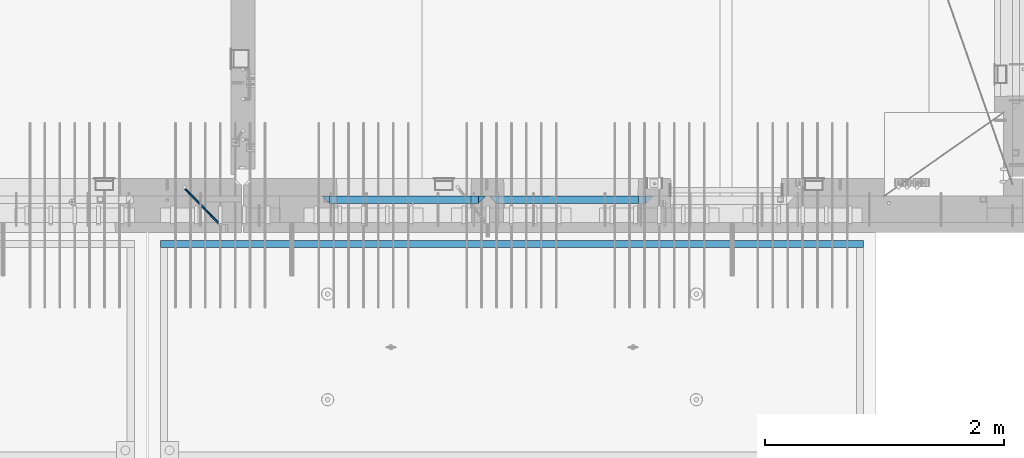
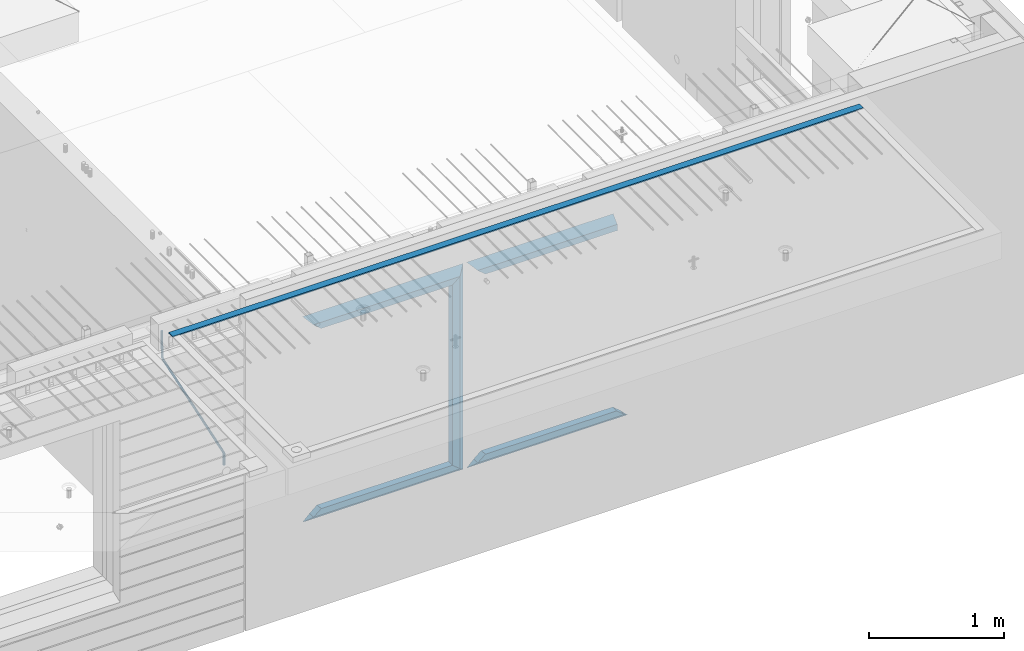
# One storey, part 97 of 352: 12 beams, 3 elements without a shape of their own.
"""IFC2X3 building model written with IfcOpenShell, lengths in millimetres."""

from ifc_helpers import new_model, si_unit, frame, origin_with_axes, place, context, subcontext, project, spatial, faceted_brep, material, type_object, element, aggregate, save


model = new_model("IFC2X3")

# Units and contexts
model_context = context("Model", 3, precision=1e-05, world=origin_with_axes())
body_context = subcontext(model_context, "Body", "Model", "MODEL_VIEW")
ifc_project = project(units=[si_unit("LENGTHUNIT", "METRE", prefix="MILLI"), si_unit("AREAUNIT", "SQUARE_METRE"), si_unit("VOLUMEUNIT", "CUBIC_METRE"), si_unit("MASSUNIT", "GRAM", prefix="KILO"), si_unit("TIMEUNIT", "SECOND"), si_unit("PLANEANGLEUNIT", "RADIAN"), si_unit("SOLIDANGLEUNIT", "STERADIAN"), si_unit("THERMODYNAMICTEMPERATUREUNIT", "DEGREE_CELSIUS"), si_unit("LUMINOUSINTENSITYUNIT", "LUMEN")], contexts=[model_context])

# Site, building, storey
site_placement = place(None, origin_with_axes())
site = spatial("IfcSite", under=ifc_project, at=site_placement, CompositionType="ELEMENT")
building_placement = place(site_placement, origin_with_axes())
building = spatial("IfcBuilding", under=site, at=building_placement, CompositionType="ELEMENT")
storey_placement = place(building_placement, origin_with_axes())
storey = spatial("IfcBuildingStorey", under=building, at=storey_placement, Name="6", CompositionType="ELEMENT", Elevation=0.0)

# Assembly, beam
assembly_1_placement = place(storey_placement, origin_with_axes())
assembly_1 = element("IfcElementAssembly", 1, at=assembly_1_placement, inside=storey, AssemblyPlace="NOTDEFINED", PredefinedType="REINFORCEMENT_UNIT")
ifc_material_1 = material()
beam_type_1 = type_object("IfcBeamType", Name="D20", PredefinedType="NOTDEFINED")
beam_1_placement = place(assembly_1_placement, frame((28120.0219996506, 7924.99999995055, 99407.5), z_axis=(-0.000415599999849952, -0.999999913638316, 0.0), x_axis=(-0.00018169900008877, 0.0, -0.999999983492737)))
beam_1 = element("IfcBeam", 2, at=beam_1_placement, type_object=beam_type_1, material=ifc_material_1, Name="JM20", ObjectType="D20", context=body_context, shape_type="Brep", body=[
    faceted_brep([(-0.00060564729210455, -9.99999998165731, 0.0), (-0.000428079845733009, -7.07106779890455, -7.07106781186667), (119.575515501536, -7.07830994756296, -7.07106481604933), (119.575337932896, -10.0072421307195, -3.43332612828817e-06), (0.0, 0.0, -10.0), (119.575943836026, -0.00724214867295814, -9.99999700418266), (0.00042843479604926, 7.07106779888636, -7.07106781186303), (119.57637202373, 7.06382565022977, -7.07106481604933), (0.00060564729210455, 9.99999998166459, 3.63797880709171e-12), (119.576549238118, 9.99275783300072, 2.99581552098971e-06), (0.000428079845733009, 7.07106779890819, 7.07106781186667), (119.576371669405, 7.06382565024978, 7.07107080768037), (0.0, 0.0, 10.0), (119.57594333493, -0.00724214864203532, 10.0000029958155), (-0.000428434810601175, -7.07106779888272, 7.07106781186667), (119.575515147211, -7.07830994754295, 7.07107080768037), (123.007838984922, -7.07805953274146, -6.96781646693489), (122.583416564885, -10.0070226667376, 0.0904895847234002), (123.182432386879, -0.00697902713727672, -9.89150957511447), (123.004922326727, 7.0640757898218, -6.96792996825661), (122.579291790258, 9.99297690664025, 0.09032907062101), (122.154869373029, 7.06401377197108, 7.14863512328429), (121.980275971029, -0.00706673364766175, 10.0723282314621), (122.157786031181, -7.0781215506031, 7.1487486246051), (232.991069545737, -7.0553235628031, -0.344989315878593), (232.56664713427, -9.98428669916029, 6.71331673826626), (233.165662947809, 0.0157569427356066, -3.26868242414184), (232.988152887861, 7.08681175970924, -0.345102817348561), (232.562522351524, 10.0157128766077, 6.71315622151724), (232.138099934426, 7.08674974201131, 13.7714622742333), (231.963506532353, 0.0156692364653281, 16.6951553824965), (232.141016592301, -7.05538558050466, 13.7715757757042), (248.076986635424, -5.5847993905918, 1.85861828010275), (247.029610002806, -8.57448599522468, 8.8259290931519), (244.875536996158, -5.81406760439131, 15.6317136598209), (242.87659436863, 1.07944012639928, 18.2892356835691), (242.20373560088, 8.06791386077748, 15.2417548051744), (243.251112233527, 11.0576004654249, 8.27444399212709), (245.405185240103, 8.29718207458427, 1.4686594254481), (247.40412786763, 1.40367434377549, -1.1888625983047), (260.566830172145, 5.47100196453175, 3.19131575132906), (262.023113325369, -1.27539050352425, 6.49949830426976), (256.884070167318, 11.8442033958454, 5.28851055269934), (253.132144174728, 14.110878827727, 11.5625744366826), (251.508879555811, 10.9432405336265, 18.3382458712176), (252.965162709021, 4.19684806558143, 21.6464284241465), (256.647922713819, -2.17635336575768, 19.5492336227662), (260.399848700399, -4.44302879667157, 13.2751697364092), (1011.72756124764, 322.959435794994, 337.688425673249), (1010.10429662876, 319.79179750097, 344.464097107826), (1010.27127809466, 329.705828263024, 334.380243120345), (1006.58851809015, 336.079029694381, 336.477437921801), (1002.83659209782, 338.345705126318, 342.751501805859), (1001.21332747894, 335.178066832297, 349.527173240437), (1002.66961063194, 328.431674364263, 352.835355793341), (1006.35237063644, 322.058472932906, 350.738160991886), (1012.15285167976, 323.143366902459, 337.876301685487), (1011.27592458235, 320.298507294498, 344.981674676291), (1011.36533099508, 330.178988123705, 334.863551186057), (1009.37468146477, 337.283999466545, 337.708251560521), (1007.34699858574, 340.296381647149, 344.744015910405), (1006.47007148832, 337.45152203918, 351.849388901209), (1007.25759217299, 330.415900817941, 354.862139400639), (1009.24824170329, 323.310889475106, 352.017439026175), (1012.6528516715, 323.14345775195, 337.876301647731), (1012.65336908352, 320.298757574768, 344.981674572278), (1012.65157305435, 330.179221832586, 334.863551088932), (1012.65028222866, 337.284594639881, 337.708251313175), (1012.64973534261, 340.297345149043, 344.744015509988), (1012.65025275464, 337.452644971851, 351.849388434534), (1012.65153137178, 330.416880891225, 354.862138993334), (1012.65282219746, 323.311508083931, 352.017438769089), (1117.44132683994, 323.162497711652, 337.876293734989), (1117.44184425197, 320.31779753447, 344.981666659536), (1117.44004822278, 330.198261792288, 334.863543176189), (1117.43875739709, 337.303634599582, 337.708243400433), (1117.43821051104, 340.316385108745, 344.744007597245), (1117.43872792307, 337.471684931556, 351.849380521792), (1117.44000654022, 330.435920850927, 354.862131080592), (1117.44129736591, 323.330548043632, 352.017430856347)], [[[0, 1, 2, 3]], [[1, 4, 5, 2]], [[4, 6, 7, 5]], [[6, 8, 9, 7]], [[8, 10, 11, 9]], [[10, 12, 13, 11]], [[12, 14, 15, 13]], [[14, 0, 3, 15]], [[14, 12, 10, 8, 6, 4, 1, 0]], [[3, 2, 16, 17]], [[2, 5, 18, 16]], [[5, 7, 19, 18]], [[7, 9, 20, 19]], [[9, 11, 21, 20]], [[11, 13, 22, 21]], [[13, 15, 23, 22]], [[15, 3, 17, 23]], [[17, 16, 24, 25]], [[16, 18, 26, 24]], [[18, 19, 27, 26]], [[19, 20, 28, 27]], [[20, 21, 29, 28]], [[21, 22, 30, 29]], [[22, 23, 31, 30]], [[23, 17, 25, 31]], [[25, 24, 32, 33]], [[31, 25, 33, 34]], [[30, 31, 34, 35]], [[29, 30, 35, 36]], [[28, 29, 36, 37]], [[27, 28, 37, 38]], [[26, 27, 38, 39]], [[24, 26, 39, 32]], [[39, 40, 41, 32]], [[38, 42, 40, 39]], [[37, 43, 42, 38]], [[36, 44, 43, 37]], [[35, 45, 44, 36]], [[34, 46, 45, 35]], [[33, 47, 46, 34]], [[32, 41, 47, 33]], [[47, 41, 48, 49]], [[41, 40, 50, 48]], [[40, 42, 51, 50]], [[42, 43, 52, 51]], [[43, 44, 53, 52]], [[44, 45, 54, 53]], [[45, 46, 55, 54]], [[46, 47, 49, 55]], [[49, 48, 56, 57]], [[48, 50, 58, 56]], [[50, 51, 59, 58]], [[51, 52, 60, 59]], [[52, 53, 61, 60]], [[53, 54, 62, 61]], [[54, 55, 63, 62]], [[55, 49, 57, 63]], [[57, 56, 64, 65]], [[56, 58, 66, 64]], [[58, 59, 67, 66]], [[59, 60, 68, 67]], [[60, 61, 69, 68]], [[61, 62, 70, 69]], [[62, 63, 71, 70]], [[63, 57, 65, 71]], [[65, 64, 72, 73]], [[64, 66, 74, 72]], [[66, 67, 75, 74]], [[67, 68, 76, 75]], [[68, 69, 77, 76]], [[69, 70, 78, 77]], [[70, 71, 79, 78]], [[71, 65, 73, 79]], [[74, 75, 76, 77, 78, 79, 73, 72]]]),
])
aggregate(assembly_1, [beam_1])

assembly_2_placement = place(storey_placement, origin_with_axes())
assembly_2 = element("IfcElementAssembly", 3, at=assembly_2_placement, inside=storey, AssemblyPlace="NOTDEFINED", PredefinedType="REINFORCEMENT_UNIT")
ifc_material_2 = material(Name="CONCRETE/Concrete_Undefined")
beam_type_2 = type_object("IfcBeamType", PredefinedType="NOTDEFINED")
beam_2_placement = place(assembly_2_placement, frame((33810.0034098489, 7449.93184428067, 99725.278844281), z_axis=(6.5298999993069e-05, -1.00000033840378e-09, 0.99999999786802), x_axis=(-0.999999997792817, 1.22639999974798e-05, 6.52989999859729e-05)))
beam_2 = element("IfcBeam", 4, at=beam_2_placement, type_object=beam_type_2, material=ifc_material_2, context=body_context, shape_type="Brep", body=[
    faceted_brep([(2.5465851649642e-11, 29.9999999999982, -4.99999999998545), (-2.91038304567337e-11, 29.9999999999982, 5.0), (5890.06001043805, 29.9999999999991, 5.00000000001455), (5890.06001043806, 30.0, -4.99999999998545), (-2.5465851649642e-11, -30.0000000000018, 5.0), (5890.06001043806, -30.0, 5.00000000001455), (2.72848410531878e-11, -30.0000000000018, -4.99999999998545), (5890.06001043806, -30.0, -5.0)], [[[0, 1, 2, 3]], [[1, 4, 5, 2]], [[4, 6, 7, 5]], [[6, 0, 3, 7]], [[5, 7, 3, 2]], [[6, 4, 1, 0]]]),
])
aggregate(assembly_2, [beam_2])

# Assembly, beams
assembly_3_placement = place(storey_placement, origin_with_axes())
assembly_3 = element("IfcElementAssembly", 5, at=assembly_3_placement, inside=storey, AssemblyPlace="NOTDEFINED", PredefinedType="REINFORCEMENT_UNIT")
ifc_material_3 = material(Name="CONCRETE/C35/45")
beam_type_3 = type_object("IfcBeamType", PredefinedType="NOTDEFINED")
beam_3_placement = place(assembly_3_placement, frame((30674.9996552717, 7820.0, 99145.0), z_axis=(0.0, 0.0, -1.0), x_axis=(1.0, 0.0, 0.0)))
beam_3 = element("IfcBeam", 6, at=beam_3_placement, type_object=beam_type_3, material=ifc_material_3, Name="SK", context=body_context, shape_type="Brep", body=[
    faceted_brep([(1249.99847412109, -30.0, 30.0), (1249.99847412109, -29.999999998452, -30.0), (1249.99847412109, 30.0, 30.0), (60.0000000000073, -30.0, 30.0), (0.0, -30.0, -30.0), (60.0000000000073, 30.0, 30.0)], [[[0, 1, 2]], [[1, 0, 3, 4]], [[2, 1, 4, 5]], [[0, 2, 5, 3]], [[5, 4, 3]]]),
])
beam_4_placement = place(assembly_3_placement, frame((30734.9996552717, 7820.0, 99085.0), z_axis=(0.0, 0.0, -1.0), x_axis=(1.0, 0.0, 0.0)))
beam_4 = element("IfcBeam", 7, at=beam_4_placement, type_object=beam_type_3, material=ifc_material_3, Name="SK", context=body_context, shape_type="Brep", body=[
    faceted_brep([(1189.99847412109, -30.0, 30.0), (1189.99847412109, -30.0, -30.0), (1189.99847412109, 30.0, -30.0), (1189.99847412109, 30.0, 30.0), (1184.32279844542, 30.0, 30.0), (1185.94442006704, -30.0, 30.0), (1184.32279844542, 29.999999998452, 25.6756756756804), (1185.94442006696, -29.999999998452, 24.0540540541406), (65.6741497967687, 29.999999998452, 25.6756756756804), (64.0525281752307, -29.999999998452, 24.0540540541406), (65.6741497967687, 29.999999998452, 26.2921283848846), (64.0525281752307, -29.999999998452, 24.9021669953072), (0.0, -30.0, -30.0), (0.0, 30.0, -30.0)], [[[0, 1, 2, 3]], [[0, 3, 4, 5]], [[5, 4, 6, 7]], [[7, 6, 8, 9]], [[9, 8, 10, 11]], [[1, 0, 5, 7, 9, 11, 12]], [[2, 1, 12, 13]], [[8, 6, 4, 3, 2, 13, 10]], [[10, 13, 12, 11]]]),
])
ifc_material_4 = material(Name="CONCRETE/C30/37")
beam_5_placement = place(assembly_3_placement, frame((32044.9981293928, 7820.0, 97350.0), z_axis=(0.0, 0.0, 1.0), x_axis=(-1.0, 3.00000001838171e-08, 0.0)))
beam_5 = element("IfcBeam", 8, at=beam_5_placement, type_object=beam_type_3, material=ifc_material_4, Name="SK", context=body_context, shape_type="Brep", body=[
    faceted_brep([(1309.99847412109, 30.0, 30.0), (1309.99847412109, -30.0, 30.0), (1369.99847412109, -30.0, -30.0), (0.0, -30.0, -30.0), (60.0000000000073, 30.0, 30.0), (60.0000000000073, -30.0, 30.0)], [[[0, 1, 2]], [[3, 4, 0, 2]], [[4, 5, 1, 0]], [[5, 3, 2, 1]], [[4, 3, 5]]]),
])
beam_6_placement = place(assembly_3_placement, frame((31984.9981293928, 7820.0, 97410.0), z_axis=(0.0, 0.0, 1.0), x_axis=(-1.0, 3.00000001838171e-08, 0.0)))
beam_6 = element("IfcBeam", 9, at=beam_6_placement, type_object=beam_type_3, material=ifc_material_4, Name="SK", context=body_context, shape_type="Brep", body=[
    faceted_brep([(1185.94594588314, -29.9999988381387, 24.0540541168593), (1184.32432432432, 29.9999988381387, 25.6756756756804), (65.6756756756768, 30.0, 25.6756756756804), (64.0540540540533, -30.0, 24.0540540540533), (1185.94594594586, -29.999999998452, 24.9021669952926), (1184.32432432433, 29.999999998452, 26.2921283848846), (1249.99847412109, -29.999999998452, -30.0), (1249.99847412109, 29.999999998452, -30.0), (0.0, -30.0, -30.0), (0.0, 30.0, -30.0), (65.6756756756768, 30.0, 26.293436281092), (64.0540540540533, -30.0, 24.9034748914419)], [[[0, 1, 2, 3]], [[1, 0, 4, 5]], [[5, 4, 6, 7]], [[8, 9, 7, 6]], [[2, 1, 5, 7, 9, 10]], [[3, 2, 10, 11]], [[6, 4, 0, 3, 11, 8]], [[8, 11, 10, 9]]]),
])
beam_7_placement = place(assembly_3_placement, frame((29275.0000367414, 7820.0, 99145.0), z_axis=(0.0, 0.0, -1.0), x_axis=(1.0, 0.0, 0.0)))
beam_7 = element("IfcBeam", 10, at=beam_7_placement, type_object=beam_type_3, material=ifc_material_3, Name="SK", context=body_context, shape_type="Brep", body=[
    faceted_brep([(60.0000000000073, 30.0, 30.0), (0.0, -30.0, -30.0), (60.0000000000073, -30.0, 30.0), (1370.00038146973, -30.0, -30.0), (1310.0003814697, -30.0, 30.0), (1310.0003814697, 30.0, 30.0)], [[[0, 1, 2]], [[2, 1, 3, 4]], [[0, 2, 4, 5]], [[1, 0, 5, 3]], [[3, 5, 4]]]),
])
beam_8_placement = place(assembly_3_placement, frame((29335.0000367414, 7820.0, 99085.0), z_axis=(0.0, 0.0, -1.0), x_axis=(1.0, 0.0, 0.0)))
beam_8 = element("IfcBeam", 11, at=beam_8_placement, type_object=beam_type_3, material=ifc_material_3, Name="SK", context=body_context, shape_type="Brep", body=[
    faceted_brep([(1185.94632735287, -29.9999988381387, 24.0540541168593), (1184.32470579405, 29.9999988381387, 25.6756756756804), (65.6760571454033, 29.9999988381387, 25.6756756756804), (64.0544355865859, -29.9999988381387, 24.0540541168593), (65.6760571454033, 29.9999988381387, 26.2937632551475), (64.0544355865859, -29.9999988381387, 24.9038019193104), (0.0, 30.0, -30.0), (0.0, -30.0, -30.0), (1250.00038146973, -29.9999988381387, -30.0), (1185.94632735287, -29.9999988381387, 24.9034749452549), (1184.32470579405, 29.9999988381387, 26.2934362810629), (1250.00038146973, 29.9999988381387, -30.0)], [[[0, 1, 2, 3]], [[3, 2, 4, 5]], [[5, 4, 6, 7]], [[0, 3, 5, 7, 8, 9]], [[1, 0, 9, 10]], [[6, 4, 2, 1, 10, 11]], [[7, 6, 11, 8]], [[8, 11, 10, 9]]]),
])
beam_9_placement = place(assembly_3_placement, frame((30615.0004182112, 7820.0, 99175.0), z_axis=(-1.0, 3.00000001838171e-08, 0.0), x_axis=(0.0, 0.0, -1.0)))
beam_9 = element("IfcBeam", 12, at=beam_9_placement, type_object=beam_type_3, material=ifc_material_3, Name="SK", context=body_context, shape_type="Brep", body=[
    faceted_brep([(60.0000000000073, 30.0, 30.0), (0.0, -30.0, -30.0), (60.0000000000073, -30.0, 30.0), (1855.0, -30.0, -30.0), (1795.00000000001, -30.0, 30.0), (1795.00000000001, 30.0, 30.0)], [[[0, 1, 2]], [[3, 4, 2, 1]], [[4, 5, 0, 2]], [[5, 3, 1, 0]], [[4, 3, 5]]]),
])
beam_10_placement = place(assembly_3_placement, frame((30645.0004182112, 7820.0, 97350.0), z_axis=(0.0, 0.0, 1.0), x_axis=(-1.0, 3.00000001838171e-08, 0.0)))
beam_10 = element("IfcBeam", 13, at=beam_10_placement, type_object=beam_type_3, material=ifc_material_4, Name="SK", context=body_context, shape_type="Brep", body=[
    faceted_brep([(1370.00038146973, -30.0, -30.0), (1310.0003814697, 30.0, 30.0), (1310.0003814697, -30.0, 30.0), (0.0, -30.0, -30.0), (60.0000000000073, 30.0, 30.0), (60.0000000000073, -30.0, 30.0)], [[[0, 1, 2]], [[3, 4, 1, 0]], [[4, 5, 2, 1]], [[5, 3, 0, 2]], [[4, 3, 5]]]),
])
beam_11_placement = place(assembly_3_placement, frame((30585.0004182112, 7820.0, 97410.0), z_axis=(0.0, 0.0, 1.0), x_axis=(-1.0, 3.00000001838171e-08, 0.0)))
beam_11 = element("IfcBeam", 14, at=beam_11_placement, type_object=beam_type_3, material=ifc_material_4, Name="SK", context=body_context, shape_type="Brep", body=[
    faceted_brep([(1185.94594588314, -29.9999988381387, 24.0540541168593), (1184.32432432432, 29.9999988381387, 25.6756756756804), (65.6756756756768, 30.0, 25.6756756756804), (64.0540540540533, -30.0, 24.0540540540533), (1185.94594588314, -29.9999988381387, 24.9038019193104), (1184.32432432432, 29.9999988381387, 26.2937632551329), (1250.00038146973, -29.9999988381387, -30.0), (1250.00038146973, 29.9999988381387, -30.0), (0.0, -30.0, -30.0), (0.0, 30.0, -30.0), (65.6756756756768, 30.0, 26.293436281092), (64.0540540540533, -30.0, 24.9034748914419)], [[[0, 1, 2, 3]], [[1, 0, 4, 5]], [[4, 6, 7, 5]], [[8, 9, 7, 6]], [[2, 1, 5, 7, 9, 10]], [[3, 2, 10, 11]], [[6, 4, 0, 3, 11, 8]], [[8, 11, 10, 9]]]),
])
beam_type_4 = type_object("IfcBeamType", PredefinedType="NOTDEFINED")
beam_12_placement = place(assembly_3_placement, frame((30550.0004182112, 7820.0, 99115.0), z_axis=(-1.0, 3.00000001838171e-08, 0.0), x_axis=(0.0, 0.0, -1.0)))
beam_12 = element("IfcBeam", 15, at=beam_12_placement, type_object=beam_type_4, material=ifc_material_3, Name="SK", context=body_context, shape_type="Brep", body=[
    faceted_brep([(0.0, -30.0, -35.0), (54.9034748914273, -30.0, 29.0540540540533), (56.2934362811066, 30.0, 30.6756756756768), (0.0, 30.0, -35.0), (1735.0, -30.0, -35.0), (1680.09652510857, -30.0, 29.0540540540533), (1678.70656371891, 30.0, 30.6756756756768), (1735.0, 30.0, -35.0)], [[[0, 1, 2, 3]], [[1, 0, 4, 5]], [[2, 1, 5, 6]], [[3, 2, 6, 7]], [[7, 4, 0, 3]], [[4, 7, 6, 5]]]),
])
aggregate(assembly_3, [beam_3, beam_4, beam_5, beam_6, beam_7, beam_8, beam_9, beam_12, beam_10, beam_11])

save(model, "model.ifc")
